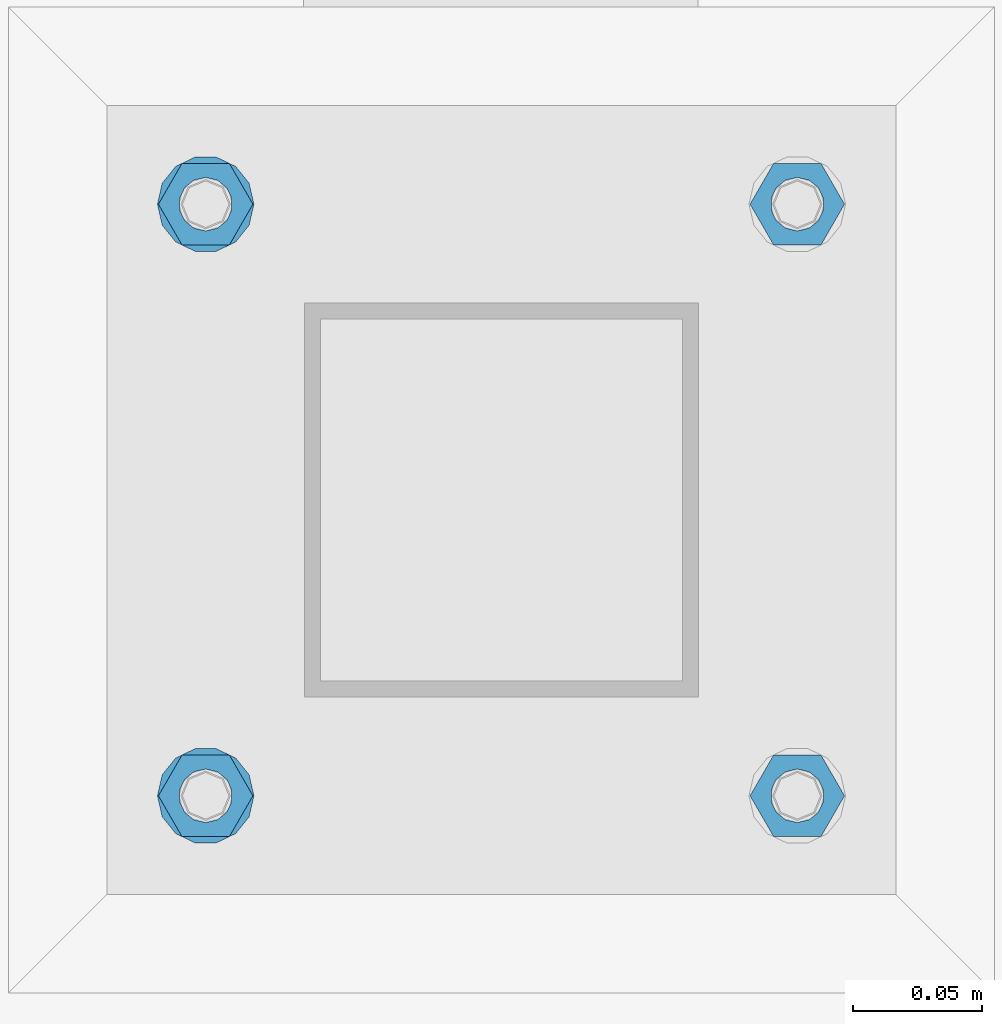
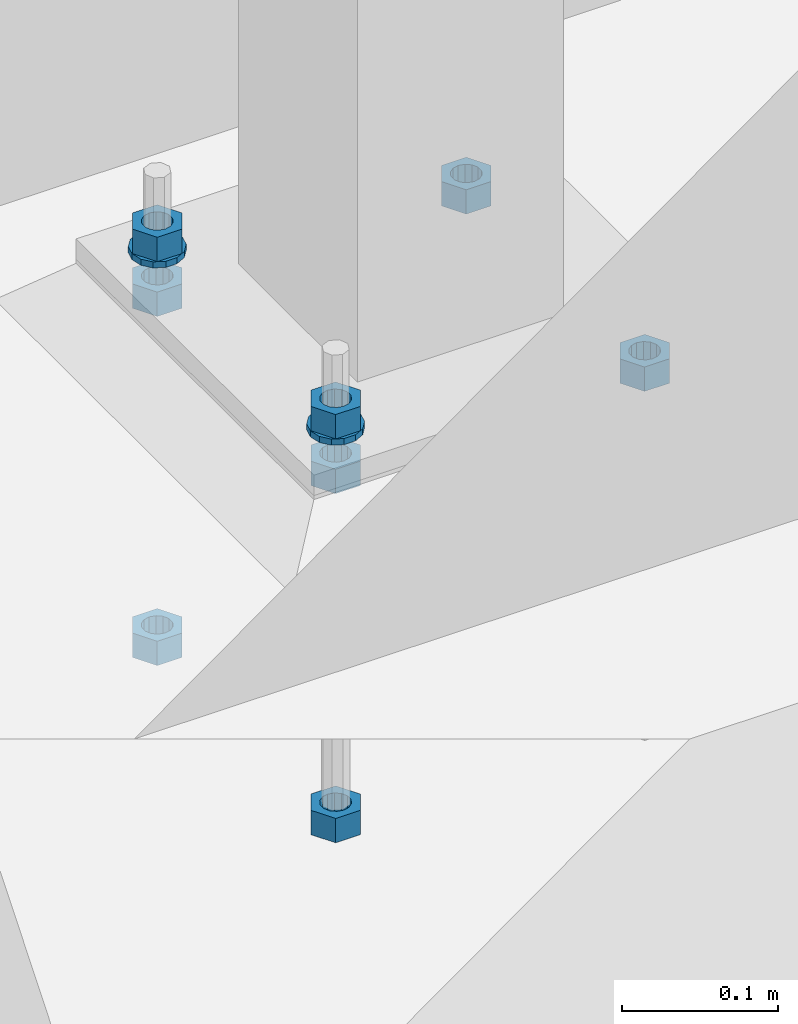
# One storey, part 955 of 1179: 10 beams, 1 element without a shape of its own.
"""IFC2X3 building model written with IfcOpenShell, lengths in millimetres."""

import ifcopenshell
import ifcopenshell.guid

model = None  # the IFC model being written
_history = None  # IfcOwnerHistory: only IFC2X3 demands one
_inside = {}  # id of a spatial element -> (the spatial element, [elements in it])
_under = {}  # id of a project, library or spatial element -> (it, [spatial elements below it])
_declared = {}  # id of a project -> (the project, [libraries it declares])
_typed = {}  # id of a type object -> (the type object, [elements of that type])
_made_of = {}  # id of a material, layer set ... -> (it, [elements and type objects made of it])


def new_model(schema):
    """Start an empty IFC model of exactly this schema.

    Asked for "IFC4X3", IfcOpenShell would pick the latest addendum, in which some entities
    have other attributes; the version numbers below select the first issue.
    IFC2X3 requires an IfcOwnerHistory on every rooted entity: one is made here for all.
    """
    global model, _history
    if schema == "IFC4X3":
        model = ifcopenshell.file(schema_version=(4, 3, 0, 0))
    else:
        model = ifcopenshell.file(schema=schema)
    _inside.clear()
    _under.clear()
    _declared.clear()
    _typed.clear()
    _made_of.clear()
    _history = None
    if model.schema == "IFC2X3":
        org = make("IfcOrganization", Name="unknown")
        user = make(
            "IfcPersonAndOrganization",
            ThePerson=make("IfcPerson", FamilyName="unknown"),
            TheOrganization=org,
        )
        app = make(
            "IfcApplication",
            ApplicationDeveloper=org,
            Version="unknown",
            ApplicationFullName="unknown",
            ApplicationIdentifier="unknown",
        )
        _history = make(
            "IfcOwnerHistory",
            OwningUser=user,
            OwningApplication=app,
            ChangeAction="ADDED",
            CreationDate=0,
        )
    return model


def make(cls, **values):
    """One entity of the class cls with the attributes given. An attribute that is None is left unset."""
    return model.create_entity(
        cls, **{name: value for name, value in values.items() if value is not None}
    )


def rooted(cls, **values):
    """An entity with a GlobalId (a new one), such as an element, a storey or a relation."""
    return make(cls, GlobalId=ifcopenshell.guid.new(), OwnerHistory=_history, **values)


def si_unit(unit_type, name, prefix=None):
    """IfcSIUnit, for example si_unit("LENGTHUNIT", "METRE", prefix="MILLI")."""
    return make("IfcSIUnit", UnitType=unit_type, Prefix=prefix, Name=name)


def assignment(units):
    """IfcUnitAssignment: the units of a project."""
    return None if units is None else make("IfcUnitAssignment", Units=units)


def point(xyz):
    """IfcCartesianPoint."""
    return None if xyz is None else make("IfcCartesianPoint", Coordinates=xyz)


def direction(xyz):
    """IfcDirection."""
    return None if xyz is None else make("IfcDirection", DirectionRatios=xyz)


def frame(location, z_axis=None, x_axis=None):
    """IfcAxis2Placement3D, a coordinate frame: its origin and axes. An axis left out is left unset."""
    return make(
        "IfcAxis2Placement3D",
        Location=point(location),
        Axis=direction(z_axis),
        RefDirection=direction(x_axis),
    )


def origin_with_axes():
    """The frame at (0, 0, 0) with the z axis (0, 0, 1) and the x axis (1, 0, 0) written out."""
    return frame((0.0, 0.0, 0.0), z_axis=(0.0, 0.0, 1.0), x_axis=(1.0, 0.0, 0.0))


def place(relative_to, where):
    """IfcLocalPlacement: puts the frame where relative to a parent placement (None: the world)."""
    return make(
        "IfcLocalPlacement", PlacementRelTo=relative_to, RelativePlacement=where
    )


def context(
    kind, dimensions, precision=None, world=None, true_north=None, identifier=None
):
    """IfcGeometricRepresentationContext, for example the 3D "Model" context."""
    return make(
        "IfcGeometricRepresentationContext",
        ContextIdentifier=identifier,
        ContextType=kind,
        CoordinateSpaceDimension=dimensions,
        Precision=precision,
        WorldCoordinateSystem=world,
        TrueNorth=true_north,
    )


def subcontext(parent, identifier, kind, view, scale=None):
    """IfcGeometricRepresentationSubContext, for example "Body" below "Model"."""
    return make(
        "IfcGeometricRepresentationSubContext",
        ContextIdentifier=identifier,
        ContextType=kind,
        ParentContext=parent,
        TargetScale=scale,
        TargetView=view,
    )


def project(units=None, contexts=None):
    """IfcProject with its units and contexts."""
    return rooted(
        "IfcProject",
        Name="project",
        RepresentationContexts=contexts,
        UnitsInContext=assignment(units),
    )


def spatial(cls, under=None, at=None, **own):
    """A site, building, storey or space (cls), placed at a placement, below another one or the project."""
    s = rooted(cls, ObjectPlacement=at, **own)
    if under is not None:
        _under.setdefault(under.id(), (under, []))[1].append(s)
    return s


def faces_of(points, faces, orient=None, outer=None):
    """IfcFace entities. A face is a list of loops; a loop is a list of indices into points, from 0.

    orient and outer hold one flag for each loop. By default every Orientation is true, the
    first loop of a face is its IfcFaceOuterBound and the others are IfcFaceBound.
    """
    made = []
    for i, loops in enumerate(faces):
        bounds = []
        for j, loop in enumerate(loops):
            is_outer = j == 0 if outer is None else outer[i][j]
            bounds.append(
                make(
                    "IfcFaceOuterBound" if is_outer else "IfcFaceBound",
                    Bound=make("IfcPolyLoop", Polygon=[points[k] for k in loop]),
                    Orientation=True if orient is None else orient[i][j],
                )
            )
        made.append(make("IfcFace", Bounds=bounds))
    return made


def faceted_brep(points, faces, orient=None, outer=None, voids=None):
    """IfcFacetedBrep: a solid bounded by flat faces; with voids (closed shells), ...WithVoids."""
    shared = [point(p) for p in points]
    hull = make("IfcClosedShell", CfsFaces=faces_of(shared, faces, orient, outer))
    if voids is None:
        return make("IfcFacetedBrep", Outer=hull)
    return make(
        "IfcFacetedBrepWithVoids",
        Outer=hull,
        Voids=[
            make(cls, CfsFaces=faces_of(shared, fs, o, b)) for cls, fs, o, b in voids
        ],
    )


def shape(context_of_items, identifier, shape_type, items):
    """IfcShapeRepresentation: the items that make up one representation, for example the "Body"."""
    return make(
        "IfcShapeRepresentation",
        ContextOfItems=context_of_items,
        RepresentationIdentifier=identifier,
        RepresentationType=shape_type,
        Items=items,
    )


def material(Name=None, Category=None):
    """IfcMaterial."""
    return make("IfcMaterial", Name=Name, Category=Category)


def made_of(thing, what):
    """Note that an element or type object is made of a material, layer set ...; save() writes the relation."""
    if what is not None:
        _made_of.setdefault(what.id(), (what, []))[1].append(thing)
    return thing


def type_object(cls, material=None, **own):
    """A type object (cls), such as IfcWallType, which elements share."""
    return made_of(rooted(cls, **own), material)


def element(
    cls,
    number,
    at=None,
    inside=None,
    cuts=None,
    type_object=None,
    material=None,
    context=None,
    identifier="Body",
    shape_type=None,
    held_by="IfcProductDefinitionShape",
    body=None,
    shapes=None,
    **own,
):
    """One element of the class cls, such as IfcWall. Its Tag is "e" and its number.

    at: its placement. inside: the storey or other place that contains it. cuts: it is an
    opening in that element (IfcRelVoidsElement). A single representation is given by context,
    identifier, shape_type and body (its items); several are given by shapes. held_by: the class
    of the entity that holds the representations. save() writes the other relations.
    """
    e = rooted(cls, Tag="e%d" % number, ObjectPlacement=at, **own)
    if body is not None:
        shapes = [shape(context, identifier, shape_type, body)]
    if shapes is not None:
        e.Representation = make(held_by, Representations=shapes)
    if inside is not None:
        _inside.setdefault(inside.id(), (inside, []))[1].append(e)
    if cuts is not None:
        rooted(
            "IfcRelVoidsElement", RelatingBuildingElement=cuts, RelatedOpeningElement=e
        )
    if type_object is not None:
        _typed.setdefault(type_object.id(), (type_object, []))[1].append(e)
    return made_of(e, material)


def aggregate(whole, parts):
    """IfcRelAggregates: a whole, such as a stair, and the parts it consists of."""
    return rooted("IfcRelAggregates", RelatingObject=whole, RelatedObjects=parts)


def save(model, path):
    """Write the relations noted so far, then the file.

    IfcRelAggregates (storeys below a building ...), IfcRelContainedInSpatialStructure (elements
    in a storey), IfcRelDefinesByType, IfcRelAssociatesMaterial and IfcRelDeclares: one each for
    every whole, place, type object, material and project.
    """
    for whole, parts in _under.values():
        aggregate(whole, parts)
    for where, things in _inside.values():
        rooted(
            "IfcRelContainedInSpatialStructure",
            RelatedElements=things,
            RelatingStructure=where,
        )
    for kind, things in _typed.values():
        rooted("IfcRelDefinesByType", RelatedObjects=things, RelatingType=kind)
    for what, things in _made_of.values():
        rooted("IfcRelAssociatesMaterial", RelatedObjects=things, RelatingMaterial=what)
    for by, libraries in _declared.values():
        rooted("IfcRelDeclares", RelatingContext=by, RelatedDefinitions=libraries)
    model.write(path)


model = new_model("IFC2X3")

# Units and contexts
model_context = context("Model", 3, precision=1e-05, world=origin_with_axes())
body_context = subcontext(model_context, "Body", "Model", "MODEL_VIEW")
ifc_project = project(units=[si_unit("LENGTHUNIT", "METRE", prefix="MILLI"), si_unit("AREAUNIT", "SQUARE_METRE"), si_unit("VOLUMEUNIT", "CUBIC_METRE"), si_unit("MASSUNIT", "GRAM", prefix="KILO"), si_unit("TIMEUNIT", "SECOND"), si_unit("PLANEANGLEUNIT", "RADIAN"), si_unit("SOLIDANGLEUNIT", "STERADIAN"), si_unit("THERMODYNAMICTEMPERATUREUNIT", "DEGREE_CELSIUS"), si_unit("LUMINOUSINTENSITYUNIT", "LUMEN")], contexts=[model_context])

# Site, building, storey
site_placement = place(None, origin_with_axes())
site = spatial("IfcSite", under=ifc_project, at=site_placement, CompositionType="ELEMENT")
building_placement = place(site_placement, origin_with_axes())
building = spatial("IfcBuilding", under=site, at=building_placement, Name="Undefined", CompositionType="ELEMENT")
storey_placement = place(building_placement, origin_with_axes())
storey = spatial("IfcBuildingStorey", under=building, at=storey_placement, Name="Undefined", CompositionType="ELEMENT", Elevation=0.0)

# Assembly, beams
assembly_placement = place(storey_placement, origin_with_axes())
assembly = element("IfcElementAssembly", 1, at=assembly_placement, inside=storey, Name="TEMPLATE", AssemblyPlace="NOTDEFINED", PredefinedType="RIGID_FRAME")
ifc_material = material(Name="STEEL/A36")
beam_type_1 = type_object("IfcBeamType", Name="3/4_HEAVY_HEX_NUT", PredefinedType="NOTDEFINED")
beam_1_placement = place(assembly_placement, frame((26682.7, 2120.9, -774.7), z_axis=(0.0, -1.0, 0.0), x_axis=(0.0, 0.0, -1.0)))
beam_1 = element("IfcBeam", 2, at=beam_1_placement, type_object=beam_type_1, material=ifc_material, Name="NUT", ObjectType="3/4_HEAVY_HEX_NUT", context=body_context, shape_type="Brep", body=[
    faceted_brep([(0.0, -18.2600002288818, 0.0), (0.0, -9.13000011444092, -15.8100004196167), (19.0499999999865, -9.13000011444092, -15.8100004196167), (19.0499999999865, -18.2600002288818, 0.0), (0.0, 9.13000011444092, -15.8100004196167), (19.0499999999865, 9.13000011444092, -15.8100004196167), (0.0, 18.2600002288818, 0.0), (19.0499999999865, 18.2600002288818, 0.0), (0.0, 9.13000011444092, 15.8100004196167), (19.0499999999865, 9.13000011444092, 15.8100004196167), (0.0, -9.13000011444092, 15.8100004196167), (19.0499999999865, -9.13000011444092, 15.8100004196167), (0.0, 0.0, 10.3199996948242), (0.0, 4.47768005528246, 9.29799844179979), (19.0499999999865, 4.47768005528246, 9.29799844179979), (19.0499999999865, 0.0, 10.3199996948242), (0.0, 8.068500660474, 6.43441456490837), (19.0499999999865, 8.068500660474, 6.43441456490837), (0.0, 10.0612557561919, 2.29641597052068), (19.0499999999865, 10.0612557561919, 2.29641597052068), (0.0, 10.0612557561919, -2.29641597052068), (19.0499999999865, 10.0612557561919, -2.29641597052068), (0.0, 8.068500660474, -6.43441456490837), (19.0499999999865, 8.068500660474, -6.43441456490837), (0.0, 4.47768005528246, -9.29799844179979), (19.0499999999865, 4.47768005528246, -9.29799844179979), (0.0, 0.0, -10.3199996948242), (19.0499999999865, 0.0, -10.3199996948242), (0.0, -4.47768005528246, -9.29799844179979), (19.0499999999865, -4.47768005528246, -9.29799844179979), (0.0, -8.068500660474, -6.43441456490837), (19.0499999999865, -8.068500660474, -6.43441456490837), (0.0, -10.0612557561919, -2.29641597052068), (19.0499999999865, -10.0612557561919, -2.29641597052068), (0.0, -10.0612557561919, 2.29641597052068), (19.0499999999865, -10.0612557561919, 2.29641597052068), (0.0, -8.068500660474, 6.43441456490837), (19.0499999999865, -8.068500660474, 6.43441456490837), (0.0, -4.47768005528246, 9.29799844179979), (19.0499999999865, -4.47768005528246, 9.29799844179979)], [[[0, 1, 2, 3]], [[1, 4, 5, 2]], [[4, 6, 7, 5]], [[6, 8, 9, 7]], [[8, 10, 11, 9]], [[10, 0, 3, 11]], [[12, 13, 14, 15]], [[13, 16, 17, 14]], [[16, 18, 19, 17]], [[18, 20, 21, 19]], [[20, 22, 23, 21]], [[22, 24, 25, 23]], [[24, 26, 27, 25]], [[26, 28, 29, 27]], [[28, 30, 31, 29]], [[30, 32, 33, 31]], [[32, 34, 35, 33]], [[34, 36, 37, 35]], [[36, 38, 39, 37]], [[38, 12, 15, 39]], [[5, 7, 9, 11, 3, 2], [17, 19, 21, 23, 25, 27, 29, 31, 33, 35, 37, 39, 15, 14]], [[10, 8, 6, 4, 1, 0], [38, 36, 34, 32, 30, 28, 26, 24, 22, 20, 18, 16, 13, 12]]]),
])
beam_2_placement = place(assembly_placement, frame((26911.3, 2120.9, -774.7), z_axis=(0.0, 1.0, 0.0), x_axis=(0.0, 0.0, -1.0)))
beam_2 = element("IfcBeam", 3, at=beam_2_placement, type_object=beam_type_1, material=ifc_material, Name="NUT", ObjectType="3/4_HEAVY_HEX_NUT", context=body_context, shape_type="Brep", body=[
    faceted_brep([(0.0, -18.2600002288818, 0.0), (0.0, -9.13000011444092, -15.8100004196167), (19.0499999999865, -9.13000011444092, -15.8100004196167), (19.0499999999865, -18.2600002288818, 0.0), (0.0, 9.13000011444092, -15.8100004196167), (19.0499999999865, 9.13000011444092, -15.8100004196167), (0.0, 18.2600002288818, 0.0), (19.0499999999865, 18.2600002288818, 0.0), (0.0, 9.13000011444092, 15.8100004196167), (19.0499999999865, 9.13000011444092, 15.8100004196167), (0.0, -9.13000011444092, 15.8100004196167), (19.0499999999865, -9.13000011444092, 15.8100004196167), (0.0, 0.0, 10.3199996948242), (0.0, 4.47768005528246, 9.29799844179979), (19.0499999999865, 4.47768005528246, 9.29799844179979), (19.0499999999865, 0.0, 10.3199996948242), (0.0, 8.068500660474, 6.43441456490837), (19.0499999999865, 8.068500660474, 6.43441456490837), (0.0, 10.0612557561919, 2.29641597052068), (19.0499999999865, 10.0612557561919, 2.29641597052068), (0.0, 10.0612557561919, -2.29641597052068), (19.0499999999865, 10.0612557561919, -2.29641597052068), (0.0, 8.068500660474, -6.43441456490837), (19.0499999999865, 8.068500660474, -6.43441456490837), (0.0, 4.47768005528246, -9.29799844179979), (19.0499999999865, 4.47768005528246, -9.29799844179979), (0.0, 0.0, -10.3199996948242), (19.0499999999865, 0.0, -10.3199996948242), (0.0, -4.47768005528246, -9.29799844179979), (19.0499999999865, -4.47768005528246, -9.29799844179979), (0.0, -8.068500660474, -6.43441456490837), (19.0499999999865, -8.068500660474, -6.43441456490837), (0.0, -10.0612557561919, -2.29641597052068), (19.0499999999865, -10.0612557561919, -2.29641597052068), (0.0, -10.0612557561919, 2.29641597052068), (19.0499999999865, -10.0612557561919, 2.29641597052068), (0.0, -8.068500660474, 6.43441456490837), (19.0499999999865, -8.068500660474, 6.43441456490837), (0.0, -4.47768005528246, 9.29799844179979), (19.0499999999865, -4.47768005528246, 9.29799844179979)], [[[0, 1, 2, 3]], [[1, 4, 5, 2]], [[4, 6, 7, 5]], [[6, 8, 9, 7]], [[8, 10, 11, 9]], [[10, 0, 3, 11]], [[12, 13, 14, 15]], [[13, 16, 17, 14]], [[16, 18, 19, 17]], [[18, 20, 21, 19]], [[20, 22, 23, 21]], [[22, 24, 25, 23]], [[24, 26, 27, 25]], [[26, 28, 29, 27]], [[28, 30, 31, 29]], [[30, 32, 33, 31]], [[32, 34, 35, 33]], [[34, 36, 37, 35]], [[36, 38, 39, 37]], [[38, 12, 15, 39]], [[5, 7, 9, 11, 3, 2], [17, 19, 21, 23, 25, 27, 29, 31, 33, 35, 37, 39, 15, 14]], [[10, 8, 6, 4, 1, 0], [38, 36, 34, 32, 30, 28, 26, 24, 22, 20, 18, 16, 13, 12]]]),
])
beam_3_placement = place(assembly_placement, frame((26682.7, 2349.5, -774.7), z_axis=(0.0, -1.0, 0.0), x_axis=(0.0, 0.0, -1.0)))
beam_3 = element("IfcBeam", 4, at=beam_3_placement, type_object=beam_type_1, material=ifc_material, Name="NUT", ObjectType="3/4_HEAVY_HEX_NUT", context=body_context, shape_type="Brep", body=[
    faceted_brep([(0.0, -18.2600002288818, 0.0), (0.0, -9.13000011444092, -15.8100004196167), (19.0499999999865, -9.13000011444092, -15.8100004196167), (19.0499999999865, -18.2600002288818, 0.0), (0.0, 9.13000011444092, -15.8100004196167), (19.0499999999865, 9.13000011444092, -15.8100004196167), (0.0, 18.2600002288818, 0.0), (19.0499999999865, 18.2600002288818, 0.0), (0.0, 9.13000011444092, 15.8100004196167), (19.0499999999865, 9.13000011444092, 15.8100004196167), (0.0, -9.13000011444092, 15.8100004196167), (19.0499999999865, -9.13000011444092, 15.8100004196167), (0.0, 0.0, 10.3199996948242), (0.0, 4.47768005528246, 9.29799844179979), (19.0499999999865, 4.47768005528246, 9.29799844179979), (19.0499999999865, 0.0, 10.3199996948242), (0.0, 8.068500660474, 6.43441456490837), (19.0499999999865, 8.068500660474, 6.43441456490837), (0.0, 10.0612557561919, 2.29641597052068), (19.0499999999865, 10.0612557561919, 2.29641597052068), (0.0, 10.0612557561919, -2.29641597052068), (19.0499999999865, 10.0612557561919, -2.29641597052068), (0.0, 8.068500660474, -6.43441456490837), (19.0499999999865, 8.068500660474, -6.43441456490837), (0.0, 4.47768005528246, -9.29799844179979), (19.0499999999865, 4.47768005528246, -9.29799844179979), (0.0, 0.0, -10.3199996948242), (19.0499999999865, 0.0, -10.3199996948242), (0.0, -4.47768005528246, -9.29799844179979), (19.0499999999865, -4.47768005528246, -9.29799844179979), (0.0, -8.068500660474, -6.43441456490837), (19.0499999999865, -8.068500660474, -6.43441456490837), (0.0, -10.0612557561919, -2.29641597052068), (19.0499999999865, -10.0612557561919, -2.29641597052068), (0.0, -10.0612557561919, 2.29641597052068), (19.0499999999865, -10.0612557561919, 2.29641597052068), (0.0, -8.068500660474, 6.43441456490837), (19.0499999999865, -8.068500660474, 6.43441456490837), (0.0, -4.47768005528246, 9.29799844179979), (19.0499999999865, -4.47768005528246, 9.29799844179979)], [[[0, 1, 2, 3]], [[1, 4, 5, 2]], [[4, 6, 7, 5]], [[6, 8, 9, 7]], [[8, 10, 11, 9]], [[10, 0, 3, 11]], [[12, 13, 14, 15]], [[13, 16, 17, 14]], [[16, 18, 19, 17]], [[18, 20, 21, 19]], [[20, 22, 23, 21]], [[22, 24, 25, 23]], [[24, 26, 27, 25]], [[26, 28, 29, 27]], [[28, 30, 31, 29]], [[30, 32, 33, 31]], [[32, 34, 35, 33]], [[34, 36, 37, 35]], [[36, 38, 39, 37]], [[38, 12, 15, 39]], [[5, 7, 9, 11, 3, 2], [17, 19, 21, 23, 25, 27, 29, 31, 33, 35, 37, 39, 15, 14]], [[10, 8, 6, 4, 1, 0], [38, 36, 34, 32, 30, 28, 26, 24, 22, 20, 18, 16, 13, 12]]]),
])
beam_4_placement = place(assembly_placement, frame((26911.3, 2349.5, -774.7), z_axis=(0.0, 1.0, 0.0), x_axis=(0.0, 0.0, -1.0)))
beam_4 = element("IfcBeam", 5, at=beam_4_placement, type_object=beam_type_1, material=ifc_material, Name="NUT", ObjectType="3/4_HEAVY_HEX_NUT", context=body_context, shape_type="Brep", body=[
    faceted_brep([(0.0, -18.2600002288818, 0.0), (0.0, -9.13000011444092, -15.8100004196167), (19.0499999999865, -9.13000011444092, -15.8100004196167), (19.0499999999865, -18.2600002288818, 0.0), (0.0, 9.13000011444092, -15.8100004196167), (19.0499999999865, 9.13000011444092, -15.8100004196167), (0.0, 18.2600002288818, 0.0), (19.0499999999865, 18.2600002288818, 0.0), (0.0, 9.13000011444092, 15.8100004196167), (19.0499999999865, 9.13000011444092, 15.8100004196167), (0.0, -9.13000011444092, 15.8100004196167), (19.0499999999865, -9.13000011444092, 15.8100004196167), (0.0, 0.0, 10.3199996948242), (0.0, 4.47768005528246, 9.29799844179979), (19.0499999999865, 4.47768005528246, 9.29799844179979), (19.0499999999865, 0.0, 10.3199996948242), (0.0, 8.068500660474, 6.43441456490837), (19.0499999999865, 8.068500660474, 6.43441456490837), (0.0, 10.0612557561919, 2.29641597052068), (19.0499999999865, 10.0612557561919, 2.29641597052068), (0.0, 10.0612557561919, -2.29641597052068), (19.0499999999865, 10.0612557561919, -2.29641597052068), (0.0, 8.068500660474, -6.43441456490837), (19.0499999999865, 8.068500660474, -6.43441456490837), (0.0, 4.47768005528246, -9.29799844179979), (19.0499999999865, 4.47768005528246, -9.29799844179979), (0.0, 0.0, -10.3199996948242), (19.0499999999865, 0.0, -10.3199996948242), (0.0, -4.47768005528246, -9.29799844179979), (19.0499999999865, -4.47768005528246, -9.29799844179979), (0.0, -8.068500660474, -6.43441456490837), (19.0499999999865, -8.068500660474, -6.43441456490837), (0.0, -10.0612557561919, -2.29641597052068), (19.0499999999865, -10.0612557561919, -2.29641597052068), (0.0, -10.0612557561919, 2.29641597052068), (19.0499999999865, -10.0612557561919, 2.29641597052068), (0.0, -8.068500660474, 6.43441456490837), (19.0499999999865, -8.068500660474, 6.43441456490837), (0.0, -4.47768005528246, 9.29799844179979), (19.0499999999865, -4.47768005528246, 9.29799844179979)], [[[0, 1, 2, 3]], [[1, 4, 5, 2]], [[4, 6, 7, 5]], [[6, 8, 9, 7]], [[8, 10, 11, 9]], [[10, 0, 3, 11]], [[12, 13, 14, 15]], [[13, 16, 17, 14]], [[16, 18, 19, 17]], [[18, 20, 21, 19]], [[20, 22, 23, 21]], [[22, 24, 25, 23]], [[24, 26, 27, 25]], [[26, 28, 29, 27]], [[28, 30, 31, 29]], [[30, 32, 33, 31]], [[32, 34, 35, 33]], [[34, 36, 37, 35]], [[36, 38, 39, 37]], [[38, 12, 15, 39]], [[5, 7, 9, 11, 3, 2], [17, 19, 21, 23, 25, 27, 29, 31, 33, 35, 37, 39, 15, 14]], [[10, 8, 6, 4, 1, 0], [38, 36, 34, 32, 30, 28, 26, 24, 22, 20, 18, 16, 13, 12]]]),
])
beam_5_placement = place(assembly_placement, frame((26682.7, 2120.9, -731.8375), z_axis=(0.0, -1.0, 0.0), x_axis=(0.0, 0.0, -1.0)))
beam_5 = element("IfcBeam", 6, at=beam_5_placement, type_object=beam_type_1, material=ifc_material, Name="NUT", ObjectType="3/4_HEAVY_HEX_NUT", context=body_context, shape_type="Brep", body=[
    faceted_brep([(0.0, -18.2600002288818, 0.0), (0.0, -9.13000011444092, -15.8100004196167), (19.0499999999865, -9.13000011444092, -15.8100004196167), (19.0499999999865, -18.2600002288818, 0.0), (0.0, 9.13000011444092, -15.8100004196167), (19.0499999999865, 9.13000011444092, -15.8100004196167), (0.0, 18.2600002288818, 0.0), (19.0499999999865, 18.2600002288818, 0.0), (0.0, 9.13000011444092, 15.8100004196167), (19.0499999999865, 9.13000011444092, 15.8100004196167), (0.0, -9.13000011444092, 15.8100004196167), (19.0499999999865, -9.13000011444092, 15.8100004196167), (0.0, 0.0, 10.3199996948242), (0.0, 4.47768005528246, 9.29799844179979), (19.0499999999865, 4.47768005528246, 9.29799844179979), (19.0499999999865, 0.0, 10.3199996948242), (0.0, 8.068500660474, 6.43441456490837), (19.0499999999865, 8.068500660474, 6.43441456490837), (0.0, 10.0612557561919, 2.29641597052068), (19.0499999999865, 10.0612557561919, 2.29641597052068), (0.0, 10.0612557561919, -2.29641597052068), (19.0499999999865, 10.0612557561919, -2.29641597052068), (0.0, 8.068500660474, -6.43441456490837), (19.0499999999865, 8.068500660474, -6.43441456490837), (0.0, 4.47768005528246, -9.29799844179979), (19.0499999999865, 4.47768005528246, -9.29799844179979), (0.0, 0.0, -10.3199996948242), (19.0499999999865, 0.0, -10.3199996948242), (0.0, -4.47768005528246, -9.29799844179979), (19.0499999999865, -4.47768005528246, -9.29799844179979), (0.0, -8.068500660474, -6.43441456490837), (19.0499999999865, -8.068500660474, -6.43441456490837), (0.0, -10.0612557561919, -2.29641597052068), (19.0499999999865, -10.0612557561919, -2.29641597052068), (0.0, -10.0612557561919, 2.29641597052068), (19.0499999999865, -10.0612557561919, 2.29641597052068), (0.0, -8.068500660474, 6.43441456490837), (19.0499999999865, -8.068500660474, 6.43441456490837), (0.0, -4.47768005528246, 9.29799844179979), (19.0499999999865, -4.47768005528246, 9.29799844179979)], [[[0, 1, 2, 3]], [[1, 4, 5, 2]], [[4, 6, 7, 5]], [[6, 8, 9, 7]], [[8, 10, 11, 9]], [[10, 0, 3, 11]], [[12, 13, 14, 15]], [[13, 16, 17, 14]], [[16, 18, 19, 17]], [[18, 20, 21, 19]], [[20, 22, 23, 21]], [[22, 24, 25, 23]], [[24, 26, 27, 25]], [[26, 28, 29, 27]], [[28, 30, 31, 29]], [[30, 32, 33, 31]], [[32, 34, 35, 33]], [[34, 36, 37, 35]], [[36, 38, 39, 37]], [[38, 12, 15, 39]], [[5, 7, 9, 11, 3, 2], [17, 19, 21, 23, 25, 27, 29, 31, 33, 35, 37, 39, 15, 14]], [[10, 8, 6, 4, 1, 0], [38, 36, 34, 32, 30, 28, 26, 24, 22, 20, 18, 16, 13, 12]]]),
])
beam_6_placement = place(assembly_placement, frame((26682.7, 2120.9, -1047.75), z_axis=(0.0, -1.0, 0.0), x_axis=(0.0, 0.0, -1.0)))
beam_6 = element("IfcBeam", 7, at=beam_6_placement, type_object=beam_type_1, material=ifc_material, Name="NUT", ObjectType="3/4_HEAVY_HEX_NUT", context=body_context, shape_type="Brep", body=[
    faceted_brep([(0.0, -18.2600002288818, 0.0), (0.0, -9.13000011444092, -15.8100004196167), (19.0499999999865, -9.13000011444092, -15.8100004196167), (19.0499999999865, -18.2600002288818, 0.0), (0.0, 9.13000011444092, -15.8100004196167), (19.0499999999865, 9.13000011444092, -15.8100004196167), (0.0, 18.2600002288818, 0.0), (19.0499999999865, 18.2600002288818, 0.0), (0.0, 9.13000011444092, 15.8100004196167), (19.0499999999865, 9.13000011444092, 15.8100004196167), (0.0, -9.13000011444092, 15.8100004196167), (19.0499999999865, -9.13000011444092, 15.8100004196167), (0.0, 0.0, 10.3199996948242), (0.0, 4.47768005528246, 9.29799844179979), (19.0499999999865, 4.47768005528246, 9.29799844179979), (19.0499999999865, 0.0, 10.3199996948242), (0.0, 8.068500660474, 6.43441456490837), (19.0499999999865, 8.068500660474, 6.43441456490837), (0.0, 10.0612557561919, 2.29641597052068), (19.0499999999865, 10.0612557561919, 2.29641597052068), (0.0, 10.0612557561919, -2.29641597052068), (19.0499999999865, 10.0612557561919, -2.29641597052068), (0.0, 8.068500660474, -6.43441456490837), (19.0499999999865, 8.068500660474, -6.43441456490837), (0.0, 4.47768005528246, -9.29799844179979), (19.0499999999865, 4.47768005528246, -9.29799844179979), (0.0, 0.0, -10.3199996948242), (19.0499999999865, 0.0, -10.3199996948242), (0.0, -4.47768005528246, -9.29799844179979), (19.0499999999865, -4.47768005528246, -9.29799844179979), (0.0, -8.068500660474, -6.43441456490837), (19.0499999999865, -8.068500660474, -6.43441456490837), (0.0, -10.0612557561919, -2.29641597052068), (19.0499999999865, -10.0612557561919, -2.29641597052068), (0.0, -10.0612557561919, 2.29641597052068), (19.0499999999865, -10.0612557561919, 2.29641597052068), (0.0, -8.068500660474, 6.43441456490837), (19.0499999999865, -8.068500660474, 6.43441456490837), (0.0, -4.47768005528246, 9.29799844179979), (19.0499999999865, -4.47768005528246, 9.29799844179979)], [[[0, 1, 2, 3]], [[1, 4, 5, 2]], [[4, 6, 7, 5]], [[6, 8, 9, 7]], [[8, 10, 11, 9]], [[10, 0, 3, 11]], [[12, 13, 14, 15]], [[13, 16, 17, 14]], [[16, 18, 19, 17]], [[18, 20, 21, 19]], [[20, 22, 23, 21]], [[22, 24, 25, 23]], [[24, 26, 27, 25]], [[26, 28, 29, 27]], [[28, 30, 31, 29]], [[30, 32, 33, 31]], [[32, 34, 35, 33]], [[34, 36, 37, 35]], [[36, 38, 39, 37]], [[38, 12, 15, 39]], [[5, 7, 9, 11, 3, 2], [17, 19, 21, 23, 25, 27, 29, 31, 33, 35, 37, 39, 15, 14]], [[10, 8, 6, 4, 1, 0], [38, 36, 34, 32, 30, 28, 26, 24, 22, 20, 18, 16, 13, 12]]]),
])
beam_7_placement = place(assembly_placement, frame((26682.7, 2349.5, -731.8375), z_axis=(0.0, -1.0, 0.0), x_axis=(0.0, 0.0, -1.0)))
beam_7 = element("IfcBeam", 8, at=beam_7_placement, type_object=beam_type_1, material=ifc_material, Name="NUT", ObjectType="3/4_HEAVY_HEX_NUT", context=body_context, shape_type="Brep", body=[
    faceted_brep([(0.0, -18.2600002288818, 0.0), (0.0, -9.13000011444092, -15.8100004196167), (19.0499999999865, -9.13000011444092, -15.8100004196167), (19.0499999999865, -18.2600002288818, 0.0), (0.0, 9.13000011444092, -15.8100004196167), (19.0499999999865, 9.13000011444092, -15.8100004196167), (0.0, 18.2600002288818, 0.0), (19.0499999999865, 18.2600002288818, 0.0), (0.0, 9.13000011444092, 15.8100004196167), (19.0499999999865, 9.13000011444092, 15.8100004196167), (0.0, -9.13000011444092, 15.8100004196167), (19.0499999999865, -9.13000011444092, 15.8100004196167), (0.0, 0.0, 10.3199996948242), (0.0, 4.47768005528246, 9.29799844179979), (19.0499999999865, 4.47768005528246, 9.29799844179979), (19.0499999999865, 0.0, 10.3199996948242), (0.0, 8.068500660474, 6.43441456490837), (19.0499999999865, 8.068500660474, 6.43441456490837), (0.0, 10.0612557561919, 2.29641597052068), (19.0499999999865, 10.0612557561919, 2.29641597052068), (0.0, 10.0612557561919, -2.29641597052068), (19.0499999999865, 10.0612557561919, -2.29641597052068), (0.0, 8.068500660474, -6.43441456490837), (19.0499999999865, 8.068500660474, -6.43441456490837), (0.0, 4.47768005528246, -9.29799844179979), (19.0499999999865, 4.47768005528246, -9.29799844179979), (0.0, 0.0, -10.3199996948242), (19.0499999999865, 0.0, -10.3199996948242), (0.0, -4.47768005528246, -9.29799844179979), (19.0499999999865, -4.47768005528246, -9.29799844179979), (0.0, -8.068500660474, -6.43441456490837), (19.0499999999865, -8.068500660474, -6.43441456490837), (0.0, -10.0612557561919, -2.29641597052068), (19.0499999999865, -10.0612557561919, -2.29641597052068), (0.0, -10.0612557561919, 2.29641597052068), (19.0499999999865, -10.0612557561919, 2.29641597052068), (0.0, -8.068500660474, 6.43441456490837), (19.0499999999865, -8.068500660474, 6.43441456490837), (0.0, -4.47768005528246, 9.29799844179979), (19.0499999999865, -4.47768005528246, 9.29799844179979)], [[[0, 1, 2, 3]], [[1, 4, 5, 2]], [[4, 6, 7, 5]], [[6, 8, 9, 7]], [[8, 10, 11, 9]], [[10, 0, 3, 11]], [[12, 13, 14, 15]], [[13, 16, 17, 14]], [[16, 18, 19, 17]], [[18, 20, 21, 19]], [[20, 22, 23, 21]], [[22, 24, 25, 23]], [[24, 26, 27, 25]], [[26, 28, 29, 27]], [[28, 30, 31, 29]], [[30, 32, 33, 31]], [[32, 34, 35, 33]], [[34, 36, 37, 35]], [[36, 38, 39, 37]], [[38, 12, 15, 39]], [[5, 7, 9, 11, 3, 2], [17, 19, 21, 23, 25, 27, 29, 31, 33, 35, 37, 39, 15, 14]], [[10, 8, 6, 4, 1, 0], [38, 36, 34, 32, 30, 28, 26, 24, 22, 20, 18, 16, 13, 12]]]),
])
beam_8_placement = place(assembly_placement, frame((26682.7, 2349.5, -1047.75), z_axis=(0.0, -1.0, 0.0), x_axis=(0.0, 0.0, -1.0)))
beam_8 = element("IfcBeam", 9, at=beam_8_placement, type_object=beam_type_1, material=ifc_material, Name="NUT", ObjectType="3/4_HEAVY_HEX_NUT", context=body_context, shape_type="Brep", body=[
    faceted_brep([(0.0, -18.2600002288818, 0.0), (0.0, -9.13000011444092, -15.8100004196167), (19.0499999999865, -9.13000011444092, -15.8100004196167), (19.0499999999865, -18.2600002288818, 0.0), (0.0, 9.13000011444092, -15.8100004196167), (19.0499999999865, 9.13000011444092, -15.8100004196167), (0.0, 18.2600002288818, 0.0), (19.0499999999865, 18.2600002288818, 0.0), (0.0, 9.13000011444092, 15.8100004196167), (19.0499999999865, 9.13000011444092, 15.8100004196167), (0.0, -9.13000011444092, 15.8100004196167), (19.0499999999865, -9.13000011444092, 15.8100004196167), (0.0, 0.0, 10.3199996948242), (0.0, 4.47768005528246, 9.29799844179979), (19.0499999999865, 4.47768005528246, 9.29799844179979), (19.0499999999865, 0.0, 10.3199996948242), (0.0, 8.068500660474, 6.43441456490837), (19.0499999999865, 8.068500660474, 6.43441456490837), (0.0, 10.0612557561919, 2.29641597052068), (19.0499999999865, 10.0612557561919, 2.29641597052068), (0.0, 10.0612557561919, -2.29641597052068), (19.0499999999865, 10.0612557561919, -2.29641597052068), (0.0, 8.068500660474, -6.43441456490837), (19.0499999999865, 8.068500660474, -6.43441456490837), (0.0, 4.47768005528246, -9.29799844179979), (19.0499999999865, 4.47768005528246, -9.29799844179979), (0.0, 0.0, -10.3199996948242), (19.0499999999865, 0.0, -10.3199996948242), (0.0, -4.47768005528246, -9.29799844179979), (19.0499999999865, -4.47768005528246, -9.29799844179979), (0.0, -8.068500660474, -6.43441456490837), (19.0499999999865, -8.068500660474, -6.43441456490837), (0.0, -10.0612557561919, -2.29641597052068), (19.0499999999865, -10.0612557561919, -2.29641597052068), (0.0, -10.0612557561919, 2.29641597052068), (19.0499999999865, -10.0612557561919, 2.29641597052068), (0.0, -8.068500660474, 6.43441456490837), (19.0499999999865, -8.068500660474, 6.43441456490837), (0.0, -4.47768005528246, 9.29799844179979), (19.0499999999865, -4.47768005528246, 9.29799844179979)], [[[0, 1, 2, 3]], [[1, 4, 5, 2]], [[4, 6, 7, 5]], [[6, 8, 9, 7]], [[8, 10, 11, 9]], [[10, 0, 3, 11]], [[12, 13, 14, 15]], [[13, 16, 17, 14]], [[16, 18, 19, 17]], [[18, 20, 21, 19]], [[20, 22, 23, 21]], [[22, 24, 25, 23]], [[24, 26, 27, 25]], [[26, 28, 29, 27]], [[28, 30, 31, 29]], [[30, 32, 33, 31]], [[32, 34, 35, 33]], [[34, 36, 37, 35]], [[36, 38, 39, 37]], [[38, 12, 15, 39]], [[5, 7, 9, 11, 3, 2], [17, 19, 21, 23, 25, 27, 29, 31, 33, 35, 37, 39, 15, 14]], [[10, 8, 6, 4, 1, 0], [38, 36, 34, 32, 30, 28, 26, 24, 22, 20, 18, 16, 13, 12]]]),
])
beam_type_2 = type_object("IfcBeamType", Name="3/4_WASHER", PredefinedType="NOTDEFINED")
beam_9_placement = place(assembly_placement, frame((26682.7, 2120.9, -750.8875), z_axis=(0.0, -1.0, 0.0), x_axis=(0.0, 0.0, -1.0)))
beam_9 = element("IfcBeam", 10, at=beam_9_placement, type_object=beam_type_2, material=ifc_material, Name="WASHER", ObjectType="3/4_WASHER", context=body_context, shape_type="Brep", body=[
    faceted_brep([(0.0, -18.6499996185303, 0.0), (0.0, -16.8030690426895, -8.09193156902893), (4.76249999999993, -16.8030690426895, -8.09193156902893), (4.76249999999993, -18.6499996185303, 0.0), (0.0, -11.6280845668225, -14.5811568497838), (4.76249999999993, -11.6280845668225, -14.5811568497838), (0.0, -4.15001533339819, -18.1824051902859), (4.76249999999993, -4.15001533339819, -18.1824051902859), (0.0, 4.15001533339819, -18.1824051902859), (4.76249999999993, 4.15001533339819, -18.1824051902859), (0.0, 11.6280845668225, -14.5811568497838), (4.76249999999993, 11.6280845668225, -14.5811568497838), (0.0, 16.8030690426895, -8.09193156902893), (4.76249999999993, 16.8030690426895, -8.09193156902893), (0.0, 18.6499996185303, 0.0), (4.76249999999993, 18.6499996185303, 0.0), (0.0, 16.8030690426895, 8.09193156902893), (4.76249999999993, 16.8030690426895, 8.09193156902893), (0.0, 11.6280845668225, 14.5811568497838), (4.76249999999993, 11.6280845668225, 14.5811568497838), (0.0, 4.15001533339819, 18.1824051902859), (4.76249999999993, 4.15001533339819, 18.1824051902859), (0.0, -4.15001533339819, 18.1824051902859), (4.76249999999993, -4.15001533339819, 18.1824051902859), (0.0, -11.6280845668225, 14.5811568497838), (4.76249999999993, -11.6280845668225, 14.5811568497838), (0.0, -16.8030690426895, 8.09193156902893), (4.76249999999993, -16.8030690426895, 8.09193156902893), (0.0, 0.0, 10.3199996948242), (0.0, 4.47768005528246, 9.29799844179979), (4.76249999999993, 4.47768005527905, 9.29799844179888), (4.76249999999993, 0.0, 10.3199996948242), (0.0, 8.068500660474, 6.43441456490837), (4.76249999999993, 8.06850066047627, 6.43441456490837), (0.0, 10.0612557561919, 2.29641597052068), (4.76249999999993, 10.0612557561908, 2.29641597052114), (0.0, 10.0612557561919, -2.29641597052068), (4.76249999999993, 10.0612557561908, -2.29641597052114), (0.0, 8.068500660474, -6.43441456490837), (4.76249999999993, 8.06850066047627, -6.43441456490791), (0.0, 4.47768005528246, -9.29799844179979), (4.76249999999993, 4.47768005527905, -9.29799844179888), (0.0, 0.0, -10.3199996948242), (4.76249999999993, 0.0, -10.3199996948242), (0.0, -4.47768005528246, -9.29799844179979), (4.76249999999993, -4.47768005527905, -9.29799844179888), (0.0, -8.068500660474, -6.43441456490837), (4.76249999999993, -8.06850066047627, -6.43441456490837), (0.0, -10.0612557561919, -2.29641597052068), (4.76249999999993, -10.0612557561908, -2.29641597052114), (0.0, -10.0612557561919, 2.29641597052068), (4.76249999999993, -10.0612557561908, 2.29641597052114), (0.0, -8.068500660474, 6.43441456490837), (4.76249999999993, -8.06850066047627, 6.43441456490791), (0.0, -4.47768005528246, 9.29799844179979), (4.76249999999993, -4.47768005527905, 9.29799844179888)], [[[0, 1, 2, 3]], [[1, 4, 5, 2]], [[4, 6, 7, 5]], [[6, 8, 9, 7]], [[8, 10, 11, 9]], [[10, 12, 13, 11]], [[12, 14, 15, 13]], [[14, 16, 17, 15]], [[16, 18, 19, 17]], [[18, 20, 21, 19]], [[20, 22, 23, 21]], [[22, 24, 25, 23]], [[24, 26, 27, 25]], [[26, 0, 3, 27]], [[28, 29, 30, 31]], [[29, 32, 33, 30]], [[32, 34, 35, 33]], [[34, 36, 37, 35]], [[36, 38, 39, 37]], [[38, 40, 41, 39]], [[40, 42, 43, 41]], [[42, 44, 45, 43]], [[44, 46, 47, 45]], [[46, 48, 49, 47]], [[48, 50, 51, 49]], [[50, 52, 53, 51]], [[52, 54, 55, 53]], [[54, 28, 31, 55]], [[5, 7, 9, 11, 13, 15, 17, 19, 21, 23, 25, 27, 3, 2], [33, 35, 37, 39, 41, 43, 45, 47, 49, 51, 53, 55, 31, 30]], [[26, 24, 22, 20, 18, 16, 14, 12, 10, 8, 6, 4, 1, 0], [54, 52, 50, 48, 46, 44, 42, 40, 38, 36, 34, 32, 29, 28]]]),
])
beam_10_placement = place(assembly_placement, frame((26682.7, 2349.5, -750.8875), z_axis=(0.0, -1.0, 0.0), x_axis=(0.0, 0.0, -1.0)))
beam_10 = element("IfcBeam", 11, at=beam_10_placement, type_object=beam_type_2, material=ifc_material, Name="WASHER", ObjectType="3/4_WASHER", context=body_context, shape_type="Brep", body=[
    faceted_brep([(0.0, -18.6499996185303, 0.0), (0.0, -16.8030690426895, -8.09193156902893), (4.76249999999993, -16.8030690426895, -8.09193156902893), (4.76249999999993, -18.6499996185303, 0.0), (0.0, -11.6280845668225, -14.5811568497838), (4.76249999999993, -11.6280845668225, -14.5811568497838), (0.0, -4.15001533339819, -18.1824051902859), (4.76249999999993, -4.15001533339819, -18.1824051902859), (0.0, 4.15001533339819, -18.1824051902859), (4.76249999999993, 4.15001533339819, -18.1824051902859), (0.0, 11.6280845668225, -14.5811568497838), (4.76249999999993, 11.6280845668225, -14.5811568497838), (0.0, 16.8030690426895, -8.09193156902893), (4.76249999999993, 16.8030690426895, -8.09193156902893), (0.0, 18.6499996185303, 0.0), (4.76249999999993, 18.6499996185303, 0.0), (0.0, 16.8030690426895, 8.09193156902893), (4.76249999999993, 16.8030690426895, 8.09193156902893), (0.0, 11.6280845668225, 14.5811568497838), (4.76249999999993, 11.6280845668225, 14.5811568497838), (0.0, 4.15001533339819, 18.1824051902859), (4.76249999999993, 4.15001533339819, 18.1824051902859), (0.0, -4.15001533339819, 18.1824051902859), (4.76249999999993, -4.15001533339819, 18.1824051902859), (0.0, -11.6280845668225, 14.5811568497838), (4.76249999999993, -11.6280845668225, 14.5811568497838), (0.0, -16.8030690426895, 8.09193156902893), (4.76249999999993, -16.8030690426895, 8.09193156902893), (0.0, 0.0, 10.3199996948242), (0.0, 4.47768005528246, 9.29799844179979), (4.76249999999993, 4.47768005527905, 9.29799844179888), (4.76249999999993, 0.0, 10.3199996948242), (0.0, 8.068500660474, 6.43441456490837), (4.76249999999993, 8.06850066047627, 6.43441456490837), (0.0, 10.0612557561919, 2.29641597052068), (4.76249999999993, 10.0612557561908, 2.29641597052114), (0.0, 10.0612557561919, -2.29641597052068), (4.76249999999993, 10.0612557561908, -2.29641597052114), (0.0, 8.068500660474, -6.43441456490837), (4.76249999999993, 8.06850066047627, -6.43441456490791), (0.0, 4.47768005528246, -9.29799844179979), (4.76249999999993, 4.47768005527905, -9.29799844179888), (0.0, 0.0, -10.3199996948242), (4.76249999999993, 0.0, -10.3199996948242), (0.0, -4.47768005528246, -9.29799844179979), (4.76249999999993, -4.47768005527905, -9.29799844179888), (0.0, -8.068500660474, -6.43441456490837), (4.76249999999993, -8.06850066047627, -6.43441456490837), (0.0, -10.0612557561919, -2.29641597052068), (4.76249999999993, -10.0612557561908, -2.29641597052114), (0.0, -10.0612557561919, 2.29641597052068), (4.76249999999993, -10.0612557561908, 2.29641597052114), (0.0, -8.068500660474, 6.43441456490837), (4.76249999999993, -8.06850066047627, 6.43441456490791), (0.0, -4.47768005528246, 9.29799844179979), (4.76249999999993, -4.47768005527905, 9.29799844179888)], [[[0, 1, 2, 3]], [[1, 4, 5, 2]], [[4, 6, 7, 5]], [[6, 8, 9, 7]], [[8, 10, 11, 9]], [[10, 12, 13, 11]], [[12, 14, 15, 13]], [[14, 16, 17, 15]], [[16, 18, 19, 17]], [[18, 20, 21, 19]], [[20, 22, 23, 21]], [[22, 24, 25, 23]], [[24, 26, 27, 25]], [[26, 0, 3, 27]], [[28, 29, 30, 31]], [[29, 32, 33, 30]], [[32, 34, 35, 33]], [[34, 36, 37, 35]], [[36, 38, 39, 37]], [[38, 40, 41, 39]], [[40, 42, 43, 41]], [[42, 44, 45, 43]], [[44, 46, 47, 45]], [[46, 48, 49, 47]], [[48, 50, 51, 49]], [[50, 52, 53, 51]], [[52, 54, 55, 53]], [[54, 28, 31, 55]], [[5, 7, 9, 11, 13, 15, 17, 19, 21, 23, 25, 27, 3, 2], [33, 35, 37, 39, 41, 43, 45, 47, 49, 51, 53, 55, 31, 30]], [[26, 24, 22, 20, 18, 16, 14, 12, 10, 8, 6, 4, 1, 0], [54, 52, 50, 48, 46, 44, 42, 40, 38, 36, 34, 32, 29, 28]]]),
])
aggregate(assembly, [beam_1, beam_2, beam_3, beam_4, beam_5, beam_9, beam_6, beam_7, beam_10, beam_8])

save(model, "model.ifc")
